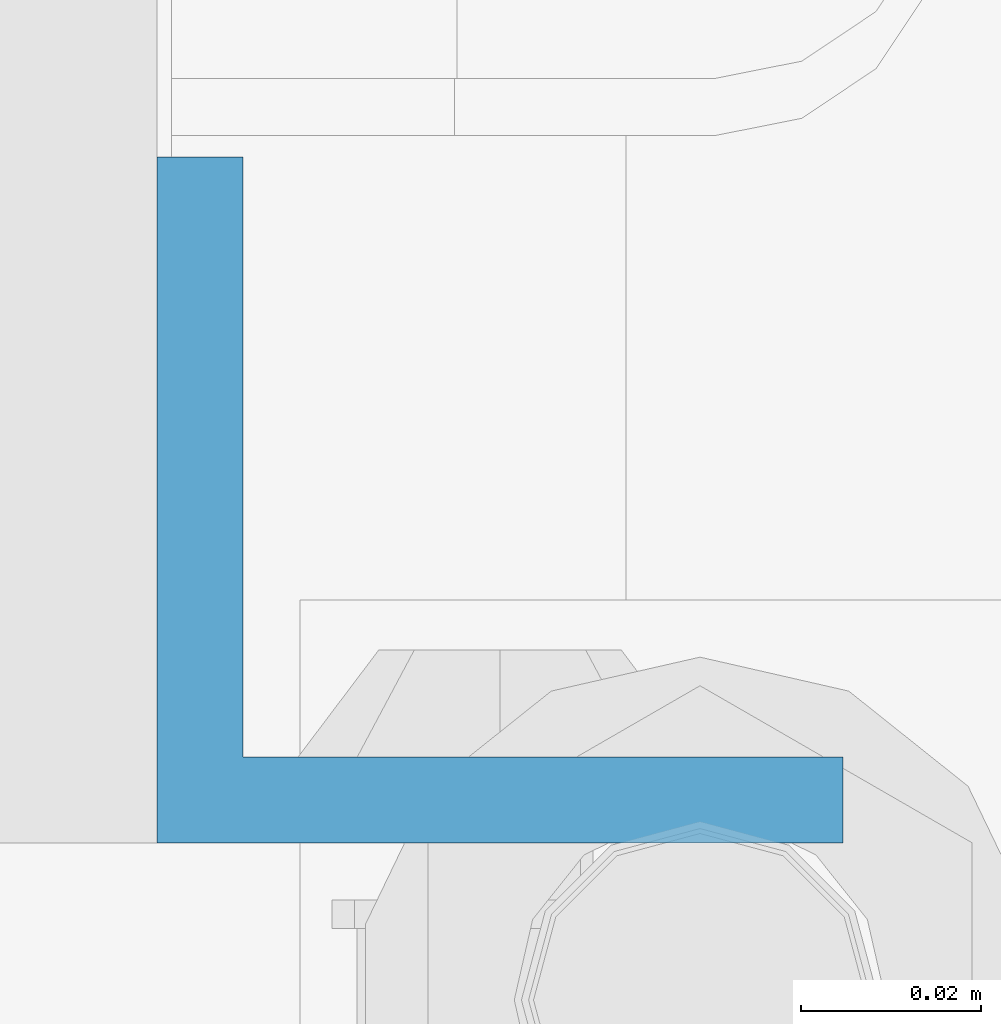
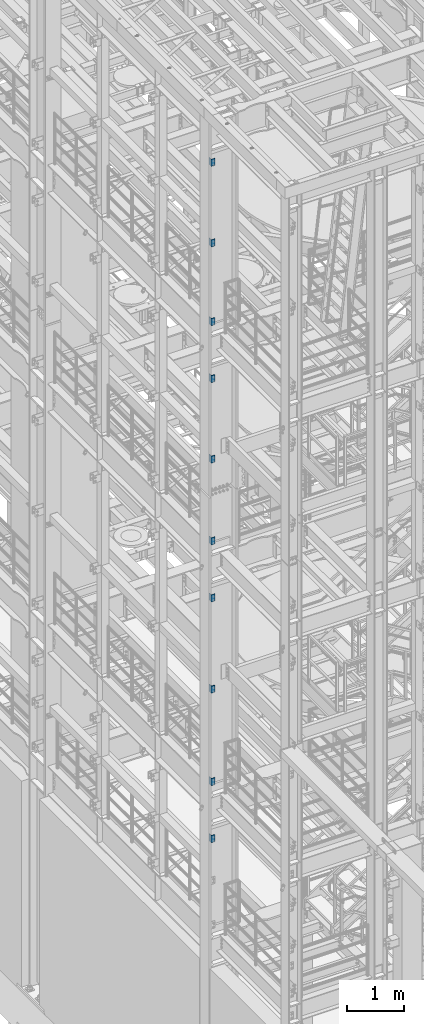
# One storey, part 1160 of 1876: 10 beams, 2 elements without a shape of their own.
"""IFC2X3 building model written with IfcOpenShell, lengths in millimetres."""

from ifc_helpers import new_model, si_unit, frame, origin_with_axes, place, context, subcontext, project, spatial, faceted_brep, material, type_object, element, aggregate, save


model = new_model("IFC2X3")

# Units and contexts
model_context = context("Model", 3, precision=1e-05, world=origin_with_axes())
body_context = subcontext(model_context, "Body", "Model", "MODEL_VIEW")
ifc_project = project(units=[si_unit("LENGTHUNIT", "METRE", prefix="MILLI"), si_unit("AREAUNIT", "SQUARE_METRE"), si_unit("VOLUMEUNIT", "CUBIC_METRE"), si_unit("MASSUNIT", "GRAM", prefix="KILO"), si_unit("TIMEUNIT", "SECOND"), si_unit("PLANEANGLEUNIT", "RADIAN"), si_unit("SOLIDANGLEUNIT", "STERADIAN"), si_unit("THERMODYNAMICTEMPERATUREUNIT", "DEGREE_CELSIUS"), si_unit("LUMINOUSINTENSITYUNIT", "LUMEN")], contexts=[model_context])

# Site, building, storey
site_placement = place(None, origin_with_axes())
site = spatial("IfcSite", under=ifc_project, at=site_placement, CompositionType="ELEMENT")
building_placement = place(site_placement, origin_with_axes())
building = spatial("IfcBuilding", under=site, at=building_placement, Name="Undefined", CompositionType="ELEMENT")
storey_placement = place(building_placement, origin_with_axes())
storey = spatial("IfcBuildingStorey", under=building, at=storey_placement, Name="Undefined", CompositionType="ELEMENT", Elevation=0.0)

# Assembly, beams
assembly_1_placement = place(storey_placement, origin_with_axes())
assembly_1 = element("IfcElementAssembly", 1, at=assembly_1_placement, inside=storey, Name="COLUMN", AssemblyPlace="NOTDEFINED", PredefinedType="RIGID_FRAME")
ifc_material = material(Name="STEEL/A36")
beam_type = type_object("IfcBeamType", Name="L3X3X3/8", PredefinedType="NOTDEFINED")
beam_1_placement = place(assembly_1_placement, frame((-212.725, -4694.2375, 21755.1), z_axis=(0.0, 1.0, 0.0), x_axis=(0.0, 0.0, -1.0)))
beam_1 = element("IfcBeam", 2, at=beam_1_placement, type_object=beam_type, material=ifc_material, Name="ANGLE", ObjectType="L3X3X3/8", context=body_context, shape_type="Brep", body=[
    faceted_brep([(0.0, 38.1000000000004, -38.1), (0.0, 38.1000000000004, 38.1), (152.4, 38.1000000000004, 38.1), (152.4, 38.1000000000004, -38.1), (0.0, 28.5749999999998, 38.1), (152.4, 28.5749999999998, 38.1), (0.0, 28.5749999999998, -28.575), (152.4, 28.5749999999998, -28.575), (0.0, -38.1000000000004, -28.575), (152.4, -38.1000000000004, -28.575), (0.0, -38.1000000000004, -38.1), (152.4, -38.1000000000004, -38.1)], [[[0, 1, 2, 3]], [[1, 4, 5, 2]], [[4, 6, 7, 5]], [[6, 8, 9, 7]], [[8, 10, 11, 9]], [[10, 0, 3, 11]], [[5, 7, 9, 11, 3, 2]], [[10, 8, 6, 4, 1, 0]]]),
])
beam_2_placement = place(assembly_1_placement, frame((-212.725, -4694.2375, 20034.25), z_axis=(0.0, 1.0, 0.0), x_axis=(0.0, 0.0, -1.0)))
beam_2 = element("IfcBeam", 3, at=beam_2_placement, type_object=beam_type, material=ifc_material, Name="ANGLE", ObjectType="L3X3X3/8", context=body_context, shape_type="Brep", body=[
    faceted_brep([(0.0, 38.1000000000004, -38.1), (0.0, 38.1000000000004, 38.1), (152.4, 38.1000000000004, 38.1), (152.4, 38.1000000000004, -38.1), (0.0, 28.5749999999998, 38.1), (152.4, 28.5749999999998, 38.1), (0.0, 28.5749999999998, -28.575), (152.4, 28.5749999999998, -28.575), (0.0, -38.1000000000004, -28.575), (152.4, -38.1000000000004, -28.575), (0.0, -38.1000000000004, -38.1), (152.4, -38.1000000000004, -38.1)], [[[0, 1, 2, 3]], [[1, 4, 5, 2]], [[4, 6, 7, 5]], [[6, 8, 9, 7]], [[8, 10, 11, 9]], [[10, 0, 3, 11]], [[5, 7, 9, 11, 3, 2]], [[10, 8, 6, 4, 1, 0]]]),
])
beam_3_placement = place(assembly_1_placement, frame((-212.725, -4694.2375, 18351.5), z_axis=(0.0, 1.0, 0.0), x_axis=(0.0, 0.0, -1.0)))
beam_3 = element("IfcBeam", 4, at=beam_3_placement, type_object=beam_type, material=ifc_material, Name="ANGLE", ObjectType="L3X3X3/8", context=body_context, shape_type="Brep", body=[
    faceted_brep([(0.0, 38.1000000000004, -38.1), (0.0, 38.1000000000004, 38.1), (152.4, 38.1000000000004, 38.1), (152.4, 38.1000000000004, -38.1), (0.0, 28.5749999999998, 38.1), (152.4, 28.5749999999998, 38.1), (0.0, 28.5749999999998, -28.575), (152.4, 28.5749999999998, -28.575), (0.0, -38.1000000000004, -28.575), (152.4, -38.1000000000004, -28.575), (0.0, -38.1000000000004, -38.1), (152.4, -38.1000000000004, -38.1)], [[[0, 1, 2, 3]], [[1, 4, 5, 2]], [[4, 6, 7, 5]], [[6, 8, 9, 7]], [[8, 10, 11, 9]], [[10, 0, 3, 11]], [[5, 7, 9, 11, 3, 2]], [[10, 8, 6, 4, 1, 0]]]),
])
beam_4_placement = place(assembly_1_placement, frame((-212.725, -4694.2375, 17132.3), z_axis=(0.0, 1.0, 0.0), x_axis=(0.0, 0.0, -1.0)))
beam_4 = element("IfcBeam", 5, at=beam_4_placement, type_object=beam_type, material=ifc_material, Name="ANGLE", ObjectType="L3X3X3/8", context=body_context, shape_type="Brep", body=[
    faceted_brep([(0.0, 38.1000000000004, -38.1), (0.0, 38.1000000000004, 38.1), (152.4, 38.1000000000004, 38.1), (152.4, 38.1000000000004, -38.1), (0.0, 28.5749999999998, 38.1), (152.4, 28.5749999999998, 38.1), (0.0, 28.5749999999998, -28.575), (152.4, 28.5749999999998, -28.575), (0.0, -38.1000000000004, -28.575), (152.4, -38.1000000000004, -28.575), (0.0, -38.1000000000004, -38.1), (152.4, -38.1000000000004, -38.1)], [[[0, 1, 2, 3]], [[1, 4, 5, 2]], [[4, 6, 7, 5]], [[6, 8, 9, 7]], [[8, 10, 11, 9]], [[10, 0, 3, 11]], [[5, 7, 9, 11, 3, 2]], [[10, 8, 6, 4, 1, 0]]]),
])
beam_5_placement = place(assembly_1_placement, frame((-212.725, -4694.2375, 15411.45), z_axis=(0.0, 1.0, 0.0), x_axis=(0.0, 0.0, -1.0)))
beam_5 = element("IfcBeam", 6, at=beam_5_placement, type_object=beam_type, material=ifc_material, Name="ANGLE", ObjectType="L3X3X3/8", context=body_context, shape_type="Brep", body=[
    faceted_brep([(0.0, 38.1000000000004, -38.1), (0.0, 38.1000000000004, 38.1), (152.4, 38.1000000000004, 38.1), (152.4, 38.1000000000004, -38.1), (0.0, 28.5749999999998, 38.1), (152.4, 28.5749999999998, 38.1), (0.0, 28.5749999999998, -28.575), (152.4, 28.5749999999998, -28.575), (0.0, -38.1000000000004, -28.575), (152.4, -38.1000000000004, -28.575), (0.0, -38.1000000000004, -38.1), (152.4, -38.1000000000004, -38.1)], [[[0, 1, 2, 3]], [[1, 4, 5, 2]], [[4, 6, 7, 5]], [[6, 8, 9, 7]], [[8, 10, 11, 9]], [[10, 0, 3, 11]], [[5, 7, 9, 11, 3, 2]], [[10, 8, 6, 4, 1, 0]]]),
])
aggregate(assembly_1, [beam_1, beam_2, beam_3, beam_4, beam_5])

assembly_2_placement = place(storey_placement, origin_with_axes())
assembly_2 = element("IfcElementAssembly", 7, at=assembly_2_placement, inside=storey, Name="COLUMN", AssemblyPlace="NOTDEFINED", PredefinedType="RIGID_FRAME")
beam_6_placement = place(assembly_2_placement, frame((-212.725, -4694.2375, 13665.2), z_axis=(0.0, 1.0, 0.0), x_axis=(0.0, 0.0, -1.0)))
beam_6 = element("IfcBeam", 8, at=beam_6_placement, type_object=beam_type, material=ifc_material, Name="ANGLE", ObjectType="L3X3X3/8", context=body_context, shape_type="Brep", body=[
    faceted_brep([(0.0, 38.1000000000004, -38.1), (0.0, 38.1000000000004, 38.1), (152.4, 38.1000000000004, 38.1), (152.4, 38.1000000000004, -38.1), (0.0, 28.5749999999998, 38.1), (152.4, 28.5749999999998, 38.1), (0.0, 28.5749999999998, -28.575), (152.4, 28.5749999999998, -28.575), (0.0, -38.1000000000004, -28.575), (152.4, -38.1000000000004, -28.575), (0.0, -38.1000000000004, -38.1), (152.4, -38.1000000000004, -38.1)], [[[0, 1, 2, 3]], [[1, 4, 5, 2]], [[4, 6, 7, 5]], [[6, 8, 9, 7]], [[8, 10, 11, 9]], [[10, 0, 3, 11]], [[5, 7, 9, 11, 3, 2]], [[10, 8, 6, 4, 1, 0]]]),
])
beam_7_placement = place(assembly_2_placement, frame((-212.725, -4694.2375, 12446.0), z_axis=(0.0, 1.0, 0.0), x_axis=(0.0, 0.0, -1.0)))
beam_7 = element("IfcBeam", 9, at=beam_7_placement, type_object=beam_type, material=ifc_material, Name="ANGLE", ObjectType="L3X3X3/8", context=body_context, shape_type="Brep", body=[
    faceted_brep([(0.0, 38.1000000000004, -38.1), (0.0, 38.1000000000004, 38.1), (152.4, 38.1000000000004, 38.1), (152.4, 38.1000000000004, -38.1), (0.0, 28.5749999999998, 38.1), (152.4, 28.5749999999998, 38.1), (0.0, 28.5749999999998, -28.575), (152.4, 28.5749999999998, -28.575), (0.0, -38.1000000000004, -28.575), (152.4, -38.1000000000004, -28.575), (0.0, -38.1000000000004, -38.1), (152.4, -38.1000000000004, -38.1)], [[[0, 1, 2, 3]], [[1, 4, 5, 2]], [[4, 6, 7, 5]], [[6, 8, 9, 7]], [[8, 10, 11, 9]], [[10, 0, 3, 11]], [[5, 7, 9, 11, 3, 2]], [[10, 8, 6, 4, 1, 0]]]),
])
beam_8_placement = place(assembly_2_placement, frame((-212.725, -4694.2375, 10496.55), z_axis=(0.0, 1.0, 0.0), x_axis=(0.0, 0.0, -1.0)))
beam_8 = element("IfcBeam", 10, at=beam_8_placement, type_object=beam_type, material=ifc_material, Name="ANGLE", ObjectType="L3X3X3/8", context=body_context, shape_type="Brep", body=[
    faceted_brep([(0.0, 38.1000000000004, -38.1), (0.0, 38.1000000000004, 38.1), (152.4, 38.1000000000004, 38.1), (152.4, 38.1000000000004, -38.1), (0.0, 28.5749999999998, 38.1), (152.4, 28.5749999999998, 38.1), (0.0, 28.5749999999998, -28.575), (152.4, 28.5749999999998, -28.575), (0.0, -38.1000000000004, -28.575), (152.4, -38.1000000000004, -28.575), (0.0, -38.1000000000004, -38.1), (152.4, -38.1000000000004, -38.1)], [[[0, 1, 2, 3]], [[1, 4, 5, 2]], [[4, 6, 7, 5]], [[6, 8, 9, 7]], [[8, 10, 11, 9]], [[10, 0, 3, 11]], [[5, 7, 9, 11, 3, 2]], [[10, 8, 6, 4, 1, 0]]]),
])
beam_9_placement = place(assembly_2_placement, frame((-212.725, -4694.2375, 8521.7), z_axis=(0.0, 1.0, 0.0), x_axis=(0.0, 0.0, -1.0)))
beam_9 = element("IfcBeam", 11, at=beam_9_placement, type_object=beam_type, material=ifc_material, Name="ANGLE", ObjectType="L3X3X3/8", context=body_context, shape_type="Brep", body=[
    faceted_brep([(0.0, 38.1000000000004, -38.1), (0.0, 38.1000000000004, 38.1), (152.4, 38.1000000000004, 38.1), (152.4, 38.1000000000004, -38.1), (0.0, 28.5749999999998, 38.1), (152.4, 28.5749999999998, 38.1), (0.0, 28.5749999999998, -28.575), (152.4, 28.5749999999998, -28.575), (0.0, -38.1000000000004, -28.575), (152.4, -38.1000000000004, -28.575), (0.0, -38.1000000000004, -38.1), (152.4, -38.1000000000004, -38.1)], [[[0, 1, 2, 3]], [[1, 4, 5, 2]], [[4, 6, 7, 5]], [[6, 8, 9, 7]], [[8, 10, 11, 9]], [[10, 0, 3, 11]], [[5, 7, 9, 11, 3, 2]], [[10, 8, 6, 4, 1, 0]]]),
])
beam_10_placement = place(assembly_2_placement, frame((-212.725, -4694.2375, 7302.5), z_axis=(0.0, 1.0, 0.0), x_axis=(0.0, 0.0, -1.0)))
beam_10 = element("IfcBeam", 12, at=beam_10_placement, type_object=beam_type, material=ifc_material, Name="ANGLE", ObjectType="L3X3X3/8", context=body_context, shape_type="Brep", body=[
    faceted_brep([(0.0, 38.1000000000004, -38.1), (0.0, 38.1000000000004, 38.1), (152.4, 38.1000000000004, 38.1), (152.4, 38.1000000000004, -38.1), (0.0, 28.5749999999998, 38.1), (152.4, 28.5749999999998, 38.1), (0.0, 28.5749999999998, -28.575), (152.4, 28.5749999999998, -28.575), (0.0, -38.1000000000004, -28.575), (152.4, -38.1000000000004, -28.575), (0.0, -38.1000000000004, -38.1), (152.4, -38.1000000000004, -38.1)], [[[0, 1, 2, 3]], [[1, 4, 5, 2]], [[4, 6, 7, 5]], [[6, 8, 9, 7]], [[8, 10, 11, 9]], [[10, 0, 3, 11]], [[5, 7, 9, 11, 3, 2]], [[10, 8, 6, 4, 1, 0]]]),
])
aggregate(assembly_2, [beam_6, beam_7, beam_8, beam_9, beam_10])

save(model, "model.ifc")
